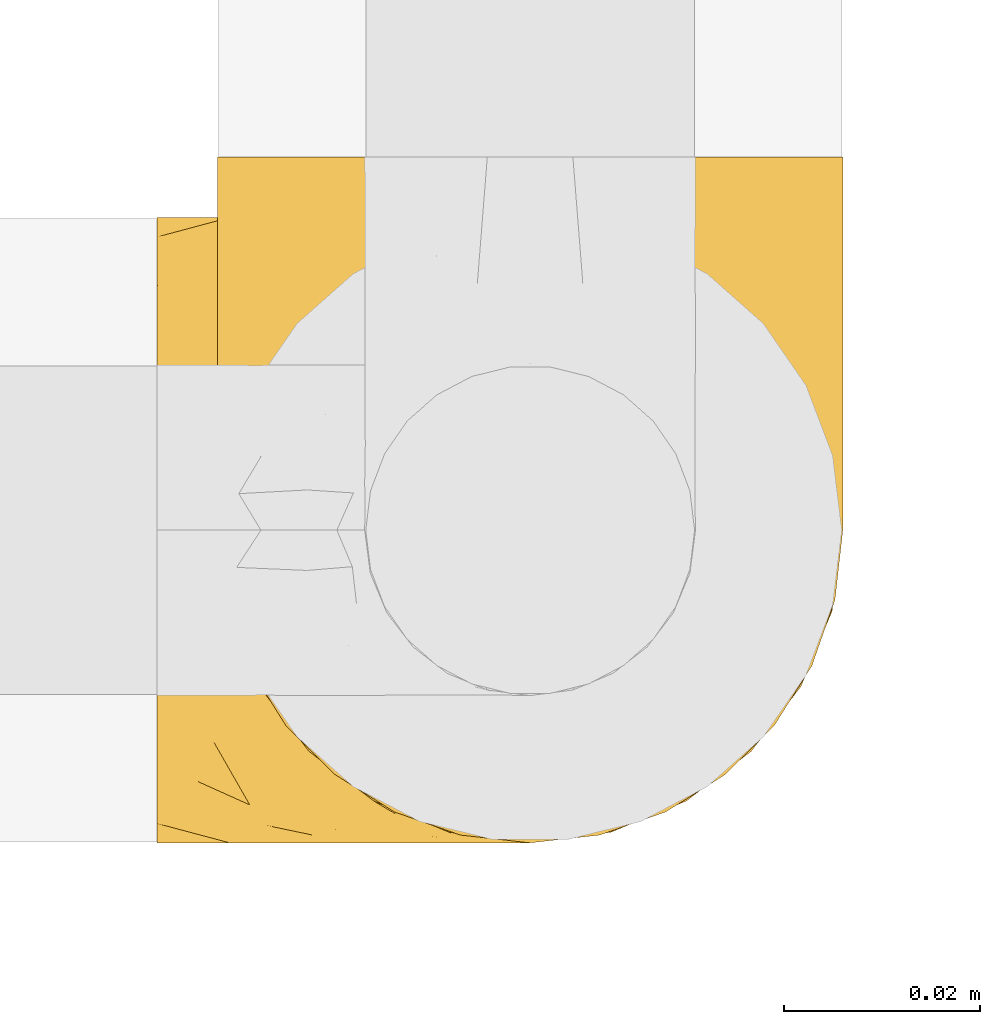
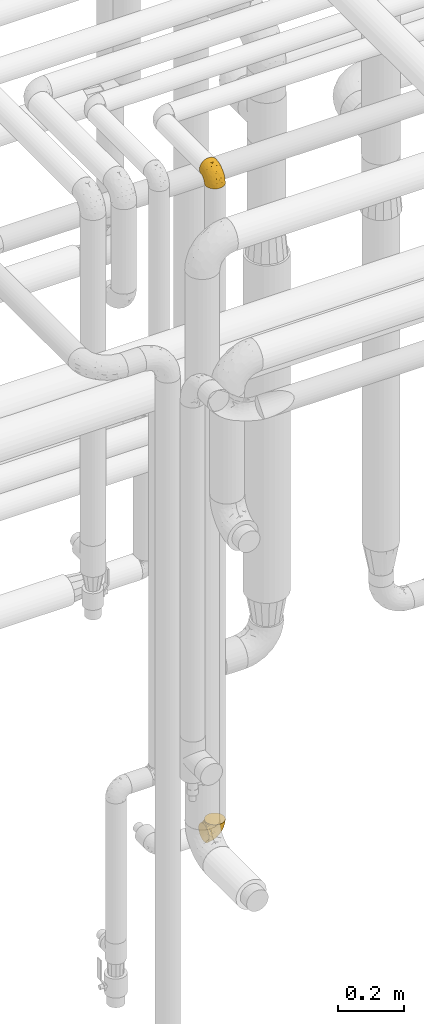
# One storey, part 437 of 827: 2 coverings.
"""IFC2X3 building model written with IfcOpenShell, lengths in millimetres."""

from ifc_helpers import new_model, entity, si_unit, converted_unit, derived_unit, direction, frame, origin, place, context, subcontext, project, spatial, faceted_brep, element, save


model = new_model("IFC2X3")

# Units and contexts
model_context = context("Model", 3, precision=0.01, world=origin(), true_north=direction((6.12303176911189e-17, 1.0)))
body_context = subcontext(model_context, "Body", "Model", "MODEL_VIEW")
ifc_project = project(units=[si_unit("LENGTHUNIT", "METRE", prefix="MILLI"), si_unit("AREAUNIT", "SQUARE_METRE"), si_unit("VOLUMEUNIT", "CUBIC_METRE"), converted_unit("PLANEANGLEUNIT", "DEGREE", entity("IfcRatioMeasure", 0.0174532925199433), si_unit("PLANEANGLEUNIT", "RADIAN"), dimensions=[0, 0, 0, 0, 0, 0, 0]), si_unit("MASSUNIT", "GRAM", prefix="KILO"), derived_unit("MASSDENSITYUNIT", [(si_unit("MASSUNIT", "GRAM", prefix="KILO"), 1), (si_unit("LENGTHUNIT", "METRE"), -3)]), derived_unit("MOMENTOFINERTIAUNIT", [(si_unit("LENGTHUNIT", "METRE"), 4)]), si_unit("TIMEUNIT", "SECOND"), si_unit("FREQUENCYUNIT", "HERTZ"), si_unit("THERMODYNAMICTEMPERATUREUNIT", "DEGREE_CELSIUS"), derived_unit("THERMALTRANSMITTANCEUNIT", [(si_unit("MASSUNIT", "GRAM", prefix="KILO"), 1), (si_unit("THERMODYNAMICTEMPERATUREUNIT", "KELVIN"), -1), (si_unit("TIMEUNIT", "SECOND"), -3)]), derived_unit("VOLUMETRICFLOWRATEUNIT", [(si_unit("LENGTHUNIT", "METRE"), 3), (si_unit("TIMEUNIT", "SECOND"), -1)]), derived_unit("MASSFLOWRATEUNIT", [(si_unit("MASSUNIT", "GRAM", prefix="KILO"), 1), (si_unit("TIMEUNIT", "SECOND"), -1)]), derived_unit("ROTATIONALFREQUENCYUNIT", [(si_unit("TIMEUNIT", "SECOND"), -1)]), si_unit("ELECTRICCURRENTUNIT", "AMPERE"), si_unit("ELECTRICVOLTAGEUNIT", "VOLT"), si_unit("POWERUNIT", "WATT"), si_unit("FORCEUNIT", "NEWTON", prefix="KILO"), si_unit("ILLUMINANCEUNIT", "LUX"), si_unit("LUMINOUSFLUXUNIT", "LUMEN"), si_unit("LUMINOUSINTENSITYUNIT", "CANDELA"), derived_unit("USERDEFINED", [(si_unit("MASSUNIT", "GRAM", prefix="KILO"), -1), (si_unit("LENGTHUNIT", "METRE"), -2), (si_unit("TIMEUNIT", "SECOND"), 3), (si_unit("LUMINOUSFLUXUNIT", "LUMEN"), 1)]), derived_unit("LINEARVELOCITYUNIT", [(si_unit("LENGTHUNIT", "METRE"), 1), (si_unit("TIMEUNIT", "SECOND"), -1)]), si_unit("PRESSUREUNIT", "PASCAL"), derived_unit("USERDEFINED", [(si_unit("LENGTHUNIT", "METRE"), -2), (si_unit("MASSUNIT", "GRAM", prefix="KILO"), 1), (si_unit("TIMEUNIT", "SECOND"), -2)]), derived_unit("LINEARFORCEUNIT", [(si_unit("MASSUNIT", "GRAM", prefix="KILO"), 1), (si_unit("LENGTHUNIT", "METRE"), 1), (si_unit("TIMEUNIT", "SECOND"), -2), (si_unit("LENGTHUNIT", "METRE"), -1)]), derived_unit("PLANARFORCEUNIT", [(si_unit("MASSUNIT", "GRAM", prefix="KILO"), 1), (si_unit("LENGTHUNIT", "METRE"), 1), (si_unit("TIMEUNIT", "SECOND"), -2), (si_unit("LENGTHUNIT", "METRE"), -2)])], contexts=[model_context])

# Site, building, storey
site_placement = place(None, origin())
site = spatial("IfcSite", under=ifc_project, at=site_placement, CompositionType="ELEMENT")
building_placement = place(site_placement, origin())
building = spatial("IfcBuilding", under=site, at=building_placement, CompositionType="ELEMENT")
storey_placement = place(building_placement, frame((0.0, 0.0, 28200.0)))
storey = spatial("IfcBuildingStorey", under=building, at=storey_placement, Name="08", CompositionType="ELEMENT", Elevation=28200.0)

# Coverings
covering_1_placement = place(storey_placement, frame((56084.69, 16164.49, 3160.4)))
element("IfcCovering", 1, at=covering_1_placement, inside=storey, Name=":ADSK_", ObjectType=":ADSK_", PredefinedType="INSULATION", context=body_context, shape_type="Brep", body=[
    faceted_brep([(40.53, 2.39, 1.6), (33.45, 1.6, 1.6), (26.35, 2.39, 1.6), (19.62, 4.75, 1.6), (13.58, 8.55, 1.6), (8.54, 13.59, 1.6), (4.75, 19.63, 1.6), (2.39, 26.36, 1.6), (1.6, 33.45, 1.6), (2.04, 37.35, 1.6), (2.39, 40.54, 1.6), (3.57, 43.9, 1.6), (4.75, 47.27, 1.6), (8.55, 53.31, 1.6), (13.59, 58.35, 1.6), (19.63, 62.14, 1.6), (26.36, 64.5, 1.6), (33.45, 65.3, 1.6), (40.54, 64.5, 1.6), (47.27, 62.14, 1.6), (53.31, 58.34, 1.6), (58.35, 53.3, 1.6), (62.14, 47.26, 1.6), (63.32, 43.89, 1.6), (64.5, 40.53, 1.6), (64.86, 37.35, 1.6), (65.08, 35.4, 1.6), (65.3, 33.45, 1.6), (64.5, 26.35, 1.6), (62.14, 19.62, 1.6), (58.34, 13.58, 1.6), (53.3, 8.54, 1.6), (47.26, 4.75, 1.6), (5.86, 71.45, 23.67), (4.27, 71.45, 27.51), (2.68, 71.45, 31.35), (2.11, 71.45, 35.67), (1.85, 71.45, 37.63), (1.6, 71.45, 39.6), (2.68, 71.45, 47.84), (5.86, 71.45, 55.52), (10.92, 71.45, 62.12), (17.52, 71.45, 67.18), (25.2, 71.45, 70.36), (33.45, 71.45, 71.45), (41.69, 71.45, 70.36), (49.37, 71.45, 67.18), (55.97, 71.45, 62.12), (61.03, 71.45, 55.52), (64.21, 71.45, 47.84), (65.3, 71.45, 39.6), (64.78, 71.45, 35.67), (64.21, 71.45, 31.35), (62.62, 71.45, 27.51), (61.03, 71.45, 23.67), (58.5, 71.45, 20.37), (55.97, 71.45, 17.07), (49.37, 71.45, 12.01), (41.69, 71.45, 8.83), (33.45, 71.45, 7.75), (25.2, 71.45, 8.83), (17.52, 71.45, 12.01), (10.92, 71.45, 17.07), (8.39, 71.45, 20.37), (64.03, 37.48, 33.94), (65.3, 38.54, 20.6), (65.3, 42.01, 24.07), (65.3, 45.49, 27.55), (65.3, 48.97, 31.03), (65.3, 52.45, 34.5), (33.45, 58.08, 68.79), (56.13, 40.84, 53.62), (61.0, 47.91, 50.17), (57.25, 55.67, 58.62), (44.44, 55.18, 67.51), (50.33, 45.13, 61.03), (51.72, 59.19, 64.5), (54.4, 11.67, 17.98), (41.87, 38.17, 61.71), (48.25, 28.82, 52.25), (64.6, 29.48, 16.72), (60.78, 32.11, 39.09), (61.71, 24.68, 25.86), (64.46, 55.82, 44.07), (55.78, 28.37, 44.36), (40.71, 9.18, 31.35), (42.87, 4.95, 17.72), (47.87, 11.17, 29.45), (62.12, 60.89, 52.37), (65.3, 55.35, 35.28), (65.3, 58.25, 36.06), (65.3, 61.15, 36.84), (65.3, 64.05, 37.61), (65.3, 65.9, 38.11), (65.3, 67.75, 38.61), (59.32, 16.27, 14.07), (49.35, 6.97, 13.65), (33.45, 4.25, 14.96), (62.53, 21.84, 13.32), (65.3, 33.94, 3.44), (65.3, 34.44, 5.29), (65.3, 35.43, 8.99), (65.3, 36.2, 11.89), (65.3, 36.98, 14.79), (65.3, 37.76, 17.69), (57.03, 18.84, 29.19), (52.84, 14.39, 28.91), (38.52, 51.68, 68.17), (33.45, 6.91, 28.33), (41.09, 26.05, 53.45), (33.45, 33.38, 58.56), (33.45, 22.05, 50.99), (44.35, 17.7, 43.14), (51.29, 19.21, 39.23), (33.45, 44.71, 66.13), (38.44, 17.7, 45.6), (33.45, 14.48, 39.66), (57.42, 66.98, 18.04), (61.06, 65.01, 22.76), (61.24, 61.98, 21.95), (64.58, 64.85, 32.18), (64.0, 62.15, 29.08), (64.21, 48.67, 20.77), (44.85, 63.81, 4.75), (61.42, 50.71, 11.03), (61.84, 48.45, 6.78), (59.03, 52.85, 5.68), (41.64, 67.6, 7.71), (38.8, 65.48, 4.42), (33.45, 67.1, 5.94), (54.12, 66.68, 14.52), (64.27, 43.2, 11.63), (63.33, 44.92, 6.6), (54.97, 58.1, 7.33), (54.91, 61.92, 12.48), (49.44, 63.17, 7.99), (49.79, 66.68, 11.14), (59.23, 56.7, 14.07), (62.42, 50.86, 15.37), (59.27, 54.42, 10.81), (64.6, 40.7, 7.89), (63.73, 57.76, 26.18), (50.25, 61.34, 5.8), (54.66, 59.9, 9.94), (62.35, 58.0, 22.23), (59.05, 62.43, 18.39), (64.34, 45.83, 17.71), (59.52, 58.99, 16.87), (63.71, 45.9, 13.24), (61.92, 67.3, 24.95), (64.52, 53.12, 26.59), (64.9, 49.43, 26.16), (63.33, 53.9, 22.11), (62.23, 52.92, 17.43), (22.04, 63.81, 4.75), (16.65, 61.35, 5.8), (17.46, 63.17, 7.99), (7.66, 56.72, 14.07), (12.13, 59.87, 10.06), (7.35, 54.39, 11.54), (25.25, 67.59, 7.71), (2.29, 40.71, 7.89), (1.6, 35.43, 8.99), (1.6, 36.2, 11.89), (1.6, 36.98, 14.79), (28.1, 65.48, 4.42), (4.51, 58.19, 22.42), (2.45, 55.78, 27.95), (5.62, 62.46, 22.22), (1.6, 69.6, 39.1), (1.6, 61.15, 36.84), (1.6, 64.05, 37.61), (1.6, 67.75, 38.61), (6.96, 67.39, 21.49), (4.16, 66.16, 26.52), (6.38, 58.11, 18.09), (7.84, 62.44, 18.39), (10.87, 61.95, 13.88), (17.1, 66.68, 11.14), (2.31, 64.85, 32.18), (1.6, 52.45, 34.5), (1.6, 48.97, 31.03), (2.62, 43.18, 11.65), (7.88, 52.88, 5.67), (5.05, 48.46, 6.81), (1.6, 34.44, 5.29), (1.6, 34.93, 7.14), (11.92, 58.11, 7.34), (1.6, 58.25, 36.06), (2.23, 60.72, 31.38), (2.95, 49.13, 19.83), (1.6, 45.49, 27.55), (3.29, 53.71, 22.94), (3.56, 44.93, 6.6), (9.57, 67.04, 17.93), (12.74, 66.6, 14.52), (2.39, 44.91, 17.45), (5.47, 50.72, 11.03), (1.6, 37.76, 17.69), (1.6, 38.54, 20.6), (3.46, 46.39, 12.33), (2.2, 57.7, 30.27), (1.6, 55.35, 35.28), (4.02, 62.73, 25.9), (1.6, 42.01, 24.07), (9.64, 55.67, 58.62), (4.35, 21.85, 13.32), (2.29, 29.49, 16.72), (2.43, 55.82, 44.07), (25.02, 38.17, 61.71), (22.45, 55.18, 67.51), (16.56, 45.12, 61.03), (5.89, 47.92, 50.18), (2.86, 37.47, 33.92), (6.1, 32.11, 39.08), (10.76, 40.85, 53.62), (28.37, 51.68, 68.17), (4.77, 60.89, 52.37), (15.17, 59.19, 64.5), (5.18, 24.69, 25.86), (7.56, 16.28, 14.07), (9.85, 18.85, 29.18), (19.01, 11.19, 29.46), (24.01, 4.95, 17.73), (26.18, 9.19, 31.37), (12.48, 11.68, 17.99), (25.8, 26.05, 53.45), (15.6, 19.23, 39.25), (14.04, 14.4, 28.92), (17.53, 6.97, 13.65), (18.64, 28.8, 52.23), (22.54, 17.7, 43.13), (11.1, 28.37, 44.36), (28.45, 17.7, 45.6)], [[[0, 1, 2, 3, 4, 5, 6, 7, 8, 9, 10, 11, 12, 13, 14, 15, 16, 17, 18, 19, 20, 21, 22, 23, 24, 25, 26, 27, 28, 29, 30, 31, 32]], [[33, 34, 35, 36, 37, 38, 39, 40, 41, 42, 43, 44, 45, 46, 47, 48, 49, 50, 51, 52, 53, 54, 55, 56, 57, 58, 59, 60, 61, 62, 63]], [[64, 65, 66, 67, 68, 69]], [[45, 44, 70]], [[71, 72, 73]], [[74, 75, 76]], [[77, 31, 30]], [[75, 78, 79]], [[27, 80, 28]], [[74, 46, 45]], [[64, 81, 82]], [[46, 76, 47]], [[83, 50, 49]], [[48, 47, 73]], [[71, 79, 84]], [[85, 86, 87]], [[49, 48, 88]], [[83, 69, 89, 90, 91, 92, 93, 94, 50]], [[95, 77, 30]], [[75, 74, 78]], [[87, 86, 96]], [[96, 86, 32]], [[96, 32, 31]], [[0, 86, 97]], [[83, 64, 69]], [[98, 80, 82]], [[73, 72, 88]], [[64, 80, 65]], [[1, 0, 97]], [[80, 27, 99, 100, 101, 102, 103, 104, 65]], [[77, 105, 106]], [[64, 82, 80]], [[70, 107, 45]], [[77, 95, 105]], [[82, 95, 98]], [[95, 30, 29]], [[74, 107, 78]], [[86, 0, 32]], [[72, 71, 81]], [[85, 108, 86]], [[76, 73, 47]], [[71, 84, 81]], [[109, 110, 111]], [[87, 112, 85]], [[79, 109, 112]], [[79, 112, 113]], [[88, 83, 49]], [[64, 83, 72]], [[31, 77, 96]], [[87, 96, 77]], [[98, 95, 29]], [[105, 95, 82]], [[81, 105, 82]], [[105, 84, 113]], [[29, 28, 98]], [[114, 107, 70]], [[80, 98, 28]], [[73, 75, 71]], [[79, 71, 75]], [[74, 76, 46]], [[73, 76, 75]], [[78, 107, 114]], [[45, 107, 74]], [[87, 113, 112]], [[115, 85, 112]], [[109, 79, 78]], [[113, 87, 106]], [[116, 115, 111]], [[116, 108, 85]], [[79, 113, 84]], [[109, 78, 110]], [[115, 109, 111]], [[85, 115, 116]], [[109, 115, 112]], [[72, 81, 64]], [[105, 81, 84]], [[73, 88, 48]], [[83, 88, 72]], [[86, 108, 97]], [[78, 114, 110]], [[113, 106, 105]], [[87, 77, 106]], [[117, 118, 119]], [[52, 120, 54, 53]], [[91, 120, 52]], [[91, 90, 120]], [[90, 121, 120]], [[122, 67, 66]], [[18, 123, 19]], [[124, 125, 126]], [[127, 59, 58]], [[128, 129, 127]], [[130, 57, 117]], [[131, 132, 125]], [[19, 133, 20]], [[128, 18, 17]], [[134, 135, 136]], [[137, 138, 139]], [[131, 103, 140]], [[22, 140, 23]], [[131, 65, 104, 103]], [[99, 27, 26, 25, 24, 101, 100]], [[141, 118, 121]], [[19, 123, 142]], [[52, 51, 50, 94, 93, 92, 91]], [[129, 128, 17]], [[117, 56, 118]], [[135, 134, 143]], [[139, 126, 133]], [[119, 144, 145]], [[127, 135, 123]], [[136, 58, 57]], [[101, 24, 23]], [[124, 138, 146]], [[140, 101, 23]], [[145, 147, 134]], [[140, 132, 131]], [[140, 103, 102, 101]], [[140, 22, 132]], [[146, 148, 124]], [[121, 69, 141]], [[55, 149, 118]], [[150, 151, 152]], [[147, 137, 134]], [[144, 150, 152]], [[152, 151, 122]], [[138, 122, 146]], [[59, 127, 129]], [[123, 18, 128]], [[58, 136, 127]], [[135, 127, 136]], [[121, 90, 89, 69]], [[120, 121, 149]], [[122, 66, 146]], [[153, 122, 138]], [[141, 69, 68]], [[127, 123, 128]], [[123, 135, 142]], [[143, 142, 135]], [[19, 142, 133]], [[66, 65, 146]], [[148, 65, 131]], [[22, 21, 132]], [[125, 132, 21]], [[126, 125, 21]], [[148, 125, 124]], [[21, 20, 126]], [[133, 126, 20]], [[139, 138, 124]], [[153, 138, 137]], [[126, 139, 124]], [[139, 133, 143]], [[147, 153, 137]], [[152, 122, 153]], [[134, 136, 130]], [[137, 139, 143]], [[144, 147, 145]], [[153, 147, 152]], [[65, 148, 146]], [[125, 148, 131]], [[141, 144, 119]], [[55, 54, 149]], [[137, 143, 134]], [[142, 143, 133]], [[130, 117, 145]], [[57, 56, 117]], [[134, 130, 145]], [[57, 130, 136]], [[150, 144, 141]], [[147, 144, 152]], [[141, 68, 150]], [[151, 68, 67]], [[117, 119, 145]], [[141, 119, 118]], [[68, 151, 150]], [[122, 151, 67]], [[118, 56, 55]], [[120, 149, 54]], [[118, 149, 121]], [[154, 155, 156]], [[157, 158, 159]], [[129, 160, 59]], [[161, 162, 163, 164]], [[165, 160, 129]], [[166, 167, 168]], [[169, 38, 37, 36, 35, 170, 171, 172]], [[63, 173, 174]], [[175, 176, 177]], [[60, 178, 61]], [[179, 35, 34, 33]], [[160, 60, 59]], [[180, 167, 181]], [[129, 17, 165]], [[182, 161, 164]], [[183, 13, 184]], [[9, 8, 185, 186, 162, 10]], [[187, 155, 15]], [[188, 179, 189]], [[187, 15, 14]], [[190, 191, 192]], [[182, 193, 161]], [[194, 176, 168]], [[176, 195, 177]], [[196, 190, 197]], [[11, 10, 162]], [[11, 161, 12]], [[187, 14, 183]], [[12, 161, 193]], [[156, 158, 177]], [[165, 17, 16]], [[194, 195, 176]], [[187, 159, 158]], [[179, 174, 189]], [[182, 164, 198, 199]], [[200, 199, 196]], [[193, 184, 13]], [[194, 168, 173]], [[201, 202, 189]], [[16, 154, 165]], [[160, 156, 178]], [[160, 165, 154]], [[178, 60, 160]], [[170, 35, 179]], [[188, 170, 179]], [[189, 174, 203]], [[174, 179, 33]], [[201, 189, 203]], [[181, 192, 191]], [[167, 180, 201]], [[192, 175, 190]], [[159, 190, 157]], [[15, 154, 16]], [[204, 196, 199]], [[204, 191, 190]], [[160, 154, 156]], [[15, 155, 154]], [[158, 155, 187]], [[203, 173, 168]], [[192, 181, 167]], [[190, 196, 204]], [[200, 196, 197]], [[184, 193, 182]], [[13, 12, 193]], [[200, 184, 182]], [[184, 200, 183]], [[187, 183, 197]], [[14, 13, 183]], [[162, 161, 11]], [[63, 62, 173]], [[174, 33, 63]], [[173, 62, 194]], [[174, 173, 203]], [[62, 61, 194]], [[195, 61, 178]], [[61, 195, 194]], [[177, 195, 178]], [[156, 177, 178]], [[175, 192, 166]], [[166, 168, 176]], [[167, 203, 168]], [[175, 166, 176]], [[167, 166, 192]], [[177, 157, 175]], [[190, 175, 157]], [[187, 197, 159]], [[190, 159, 197]], [[177, 158, 157]], [[155, 158, 156]], [[167, 201, 203]], [[200, 197, 183]], [[202, 201, 180]], [[202, 188, 189]], [[199, 200, 182]], [[41, 40, 205]], [[206, 207, 7]], [[208, 38, 169, 172, 171, 170, 188, 202, 180]], [[209, 210, 211]], [[212, 213, 214]], [[212, 215, 205]], [[43, 210, 216]], [[217, 40, 39]], [[216, 114, 70]], [[208, 213, 212]], [[205, 40, 217]], [[218, 42, 41]], [[216, 209, 114]], [[42, 218, 210]], [[214, 213, 219]], [[219, 220, 221]], [[199, 207, 213]], [[213, 207, 219]], [[8, 7, 207]], [[222, 223, 224]], [[4, 225, 5]], [[2, 97, 223]], [[110, 226, 111]], [[225, 220, 5]], [[227, 221, 228]], [[223, 229, 3]], [[2, 223, 3]], [[230, 231, 226]], [[224, 223, 108]], [[42, 210, 43]], [[230, 209, 211]], [[222, 225, 229]], [[38, 208, 39]], [[3, 229, 4]], [[213, 180, 181, 191, 204, 199]], [[220, 206, 6]], [[5, 220, 6]], [[207, 199, 198, 164, 163, 162, 186, 185, 8]], [[212, 214, 215]], [[218, 205, 211]], [[211, 215, 230]], [[226, 110, 209]], [[222, 231, 227]], [[222, 224, 231]], [[213, 208, 180]], [[217, 208, 212]], [[222, 229, 223]], [[225, 4, 229]], [[221, 220, 225]], [[206, 220, 219]], [[228, 221, 225]], [[214, 221, 232]], [[207, 206, 219]], [[44, 43, 70]], [[7, 6, 206]], [[230, 215, 232]], [[211, 205, 215]], [[205, 218, 41]], [[210, 218, 211]], [[43, 216, 70]], [[209, 216, 210]], [[233, 116, 111]], [[230, 232, 227]], [[224, 116, 233]], [[230, 226, 209]], [[224, 108, 116]], [[230, 227, 231]], [[221, 227, 232]], [[233, 226, 231]], [[225, 222, 228]], [[226, 233, 111]], [[224, 233, 231]], [[221, 214, 219]], [[214, 232, 215]], [[208, 217, 39]], [[205, 217, 212]], [[97, 2, 1]], [[97, 108, 223]], [[110, 114, 209]], [[227, 228, 222]]]),
])
covering_2_placement = place(storey_placement, frame((56078.54, 16164.49, 751.3)))
element("IfcCovering", 2, at=covering_2_placement, inside=storey, Name=":ADSK_", ObjectType=":ADSK_", PredefinedType="INSULATION", context=body_context, shape_type="Brep", body=[
    faceted_brep([(1.6, 40.53, 2.39), (1.6, 33.45, 1.6), (1.6, 26.35, 2.39), (1.6, 19.62, 4.75), (1.6, 13.58, 8.55), (1.6, 8.54, 13.59), (1.6, 4.75, 19.63), (1.6, 2.39, 26.36), (1.6, 1.6, 33.45), (1.6, 2.04, 37.35), (1.6, 2.39, 40.54), (1.6, 3.57, 43.9), (1.6, 4.75, 47.27), (1.6, 8.55, 53.31), (1.6, 13.59, 58.35), (1.6, 19.63, 62.14), (1.6, 26.36, 64.5), (1.6, 33.45, 65.3), (1.6, 40.54, 64.5), (1.6, 47.27, 62.14), (1.6, 53.31, 58.34), (1.6, 58.35, 53.3), (1.6, 62.14, 47.26), (1.6, 63.32, 43.89), (1.6, 64.5, 40.53), (1.6, 64.86, 37.35), (1.6, 65.08, 35.4), (1.6, 65.3, 33.45), (1.6, 64.5, 26.35), (1.6, 62.14, 19.62), (1.6, 58.34, 13.58), (1.6, 53.3, 8.54), (1.6, 47.26, 4.75), (23.67, 5.86, 71.45), (27.51, 4.27, 71.45), (31.35, 2.68, 71.45), (35.67, 2.11, 71.45), (37.63, 1.85, 71.45), (39.6, 1.6, 71.45), (47.84, 2.68, 71.45), (55.52, 5.86, 71.45), (62.12, 10.92, 71.45), (67.18, 17.52, 71.45), (70.36, 25.2, 71.45), (71.45, 33.45, 71.45), (70.36, 41.69, 71.45), (67.18, 49.37, 71.45), (62.12, 55.97, 71.45), (55.52, 61.03, 71.45), (47.84, 64.21, 71.45), (39.6, 65.3, 71.45), (35.67, 64.78, 71.45), (31.35, 64.21, 71.45), (27.51, 62.62, 71.45), (23.67, 61.03, 71.45), (20.37, 58.5, 71.45), (17.07, 55.97, 71.45), (12.01, 49.37, 71.45), (8.83, 41.69, 71.45), (7.75, 33.45, 71.45), (8.83, 25.2, 71.45), (12.01, 17.52, 71.45), (17.07, 10.92, 71.45), (20.37, 8.39, 71.45), (33.94, 64.03, 37.48), (20.6, 65.3, 38.54), (24.07, 65.3, 42.01), (27.55, 65.3, 45.49), (31.03, 65.3, 48.97), (34.5, 65.3, 52.45), (68.79, 33.45, 58.08), (53.62, 56.13, 40.84), (50.17, 61.0, 47.91), (58.62, 57.25, 55.67), (67.51, 44.44, 55.18), (61.03, 50.33, 45.13), (64.5, 51.72, 59.19), (17.98, 54.4, 11.67), (61.71, 41.87, 38.17), (52.25, 48.25, 28.82), (16.72, 64.6, 29.48), (39.09, 60.78, 32.11), (25.86, 61.71, 24.68), (44.07, 64.46, 55.82), (44.36, 55.78, 28.37), (31.35, 40.71, 9.18), (17.72, 42.87, 4.95), (29.45, 47.87, 11.17), (52.37, 62.12, 60.89), (35.28, 65.3, 55.35), (36.06, 65.3, 58.25), (36.84, 65.3, 61.15), (37.61, 65.3, 64.05), (38.11, 65.3, 65.9), (38.61, 65.3, 67.75), (14.07, 59.32, 16.27), (13.65, 49.35, 6.97), (14.96, 33.45, 4.25), (13.32, 62.53, 21.84), (3.44, 65.3, 33.94), (5.29, 65.3, 34.44), (8.99, 65.3, 35.43), (11.89, 65.3, 36.2), (14.79, 65.3, 36.98), (17.69, 65.3, 37.76), (29.19, 57.03, 18.84), (28.91, 52.84, 14.39), (68.17, 38.52, 51.68), (28.33, 33.45, 6.91), (53.45, 41.09, 26.05), (58.56, 33.45, 33.38), (50.99, 33.45, 22.05), (43.14, 44.35, 17.7), (39.23, 51.29, 19.21), (66.13, 33.45, 44.71), (45.6, 38.44, 17.7), (39.66, 33.45, 14.48), (18.04, 57.42, 66.98), (22.76, 61.06, 65.01), (21.95, 61.24, 61.98), (32.18, 64.58, 64.85), (29.08, 64.0, 62.15), (20.77, 64.21, 48.67), (4.75, 44.85, 63.81), (11.03, 61.42, 50.71), (6.78, 61.84, 48.45), (5.68, 59.03, 52.85), (7.71, 41.64, 67.6), (4.42, 38.8, 65.48), (5.94, 33.45, 67.1), (14.52, 54.12, 66.68), (11.63, 64.27, 43.2), (6.6, 63.33, 44.92), (7.33, 54.97, 58.1), (12.48, 54.91, 61.92), (7.99, 49.44, 63.17), (11.14, 49.79, 66.68), (14.07, 59.23, 56.7), (15.37, 62.42, 50.86), (10.81, 59.27, 54.42), (7.89, 64.6, 40.7), (26.18, 63.73, 57.76), (5.8, 50.25, 61.34), (9.94, 54.66, 59.9), (22.23, 62.35, 58.0), (18.39, 59.05, 62.43), (17.71, 64.34, 45.83), (16.87, 59.52, 58.99), (13.24, 63.71, 45.9), (24.95, 61.92, 67.3), (26.59, 64.52, 53.12), (26.16, 64.9, 49.43), (22.11, 63.33, 53.9), (17.43, 62.23, 52.92), (4.75, 22.04, 63.81), (5.8, 16.65, 61.35), (7.99, 17.46, 63.17), (14.07, 7.66, 56.72), (10.06, 12.13, 59.87), (11.54, 7.35, 54.39), (7.71, 25.25, 67.59), (7.89, 2.29, 40.71), (8.99, 1.6, 35.43), (11.89, 1.6, 36.2), (14.79, 1.6, 36.98), (4.42, 28.1, 65.48), (22.42, 4.51, 58.19), (27.95, 2.45, 55.78), (22.22, 5.62, 62.46), (36.84, 1.6, 61.15), (37.61, 1.6, 64.05), (38.61, 1.6, 67.75), (39.1, 1.6, 69.6), (21.49, 6.96, 67.39), (26.52, 4.16, 66.16), (18.09, 6.38, 58.11), (18.39, 7.84, 62.44), (13.88, 10.87, 61.95), (11.14, 17.1, 66.68), (32.18, 2.31, 64.85), (34.5, 1.6, 52.45), (31.03, 1.6, 48.97), (11.65, 2.62, 43.18), (5.67, 7.88, 52.88), (6.81, 5.05, 48.46), (5.29, 1.6, 34.44), (7.14, 1.6, 34.93), (7.34, 11.92, 58.11), (36.06, 1.6, 58.25), (31.38, 2.23, 60.72), (19.83, 2.95, 49.13), (27.55, 1.6, 45.49), (22.94, 3.29, 53.71), (6.6, 3.56, 44.93), (17.93, 9.57, 67.04), (14.52, 12.74, 66.6), (17.45, 2.39, 44.91), (11.03, 5.47, 50.72), (17.69, 1.6, 37.76), (20.6, 1.6, 38.54), (12.33, 3.46, 46.39), (25.9, 4.02, 62.73), (30.27, 2.2, 57.7), (35.28, 1.6, 55.35), (24.07, 1.6, 42.01), (58.62, 9.64, 55.67), (13.32, 4.35, 21.85), (16.72, 2.29, 29.49), (44.07, 2.43, 55.82), (61.71, 25.02, 38.17), (67.51, 22.45, 55.18), (61.03, 16.56, 45.12), (50.18, 5.89, 47.92), (33.92, 2.86, 37.47), (39.08, 6.1, 32.11), (53.62, 10.76, 40.85), (68.17, 28.37, 51.68), (52.37, 4.77, 60.89), (64.5, 15.17, 59.19), (25.86, 5.18, 24.69), (14.07, 7.56, 16.28), (29.18, 9.85, 18.85), (29.46, 19.01, 11.19), (17.73, 24.01, 4.95), (31.37, 26.18, 9.19), (17.99, 12.48, 11.68), (53.45, 25.8, 26.05), (39.25, 15.6, 19.23), (28.92, 14.04, 14.4), (13.65, 17.53, 6.97), (52.23, 18.64, 28.8), (43.13, 22.54, 17.7), (44.36, 11.1, 28.37), (45.6, 28.45, 17.7)], [[[0, 1, 2, 3, 4, 5, 6, 7, 8, 9, 10, 11, 12, 13, 14, 15, 16, 17, 18, 19, 20, 21, 22, 23, 24, 25, 26, 27, 28, 29, 30, 31, 32]], [[33, 34, 35, 36, 37, 38, 39, 40, 41, 42, 43, 44, 45, 46, 47, 48, 49, 50, 51, 52, 53, 54, 55, 56, 57, 58, 59, 60, 61, 62, 63]], [[64, 65, 66, 67, 68, 69]], [[45, 44, 70]], [[71, 72, 73]], [[74, 75, 76]], [[77, 31, 30]], [[75, 78, 79]], [[27, 80, 28]], [[74, 46, 45]], [[64, 81, 82]], [[46, 76, 47]], [[83, 50, 49]], [[48, 47, 73]], [[71, 79, 84]], [[85, 86, 87]], [[49, 48, 88]], [[83, 69, 89, 90, 91, 92, 93, 94, 50]], [[95, 77, 30]], [[75, 74, 78]], [[87, 86, 96]], [[96, 86, 32]], [[96, 32, 31]], [[0, 86, 97]], [[83, 64, 69]], [[98, 80, 82]], [[73, 72, 88]], [[64, 80, 65]], [[1, 0, 97]], [[80, 27, 99, 100, 101, 102, 103, 104, 65]], [[77, 105, 106]], [[64, 82, 80]], [[70, 107, 45]], [[77, 95, 105]], [[82, 95, 98]], [[95, 30, 29]], [[74, 107, 78]], [[86, 0, 32]], [[72, 71, 81]], [[85, 108, 86]], [[76, 73, 47]], [[71, 84, 81]], [[109, 110, 111]], [[87, 112, 85]], [[79, 109, 112]], [[79, 112, 113]], [[88, 83, 49]], [[64, 83, 72]], [[31, 77, 96]], [[87, 96, 77]], [[98, 95, 29]], [[105, 95, 82]], [[81, 105, 82]], [[105, 84, 113]], [[29, 28, 98]], [[114, 107, 70]], [[80, 98, 28]], [[73, 75, 71]], [[79, 71, 75]], [[74, 76, 46]], [[73, 76, 75]], [[78, 107, 114]], [[45, 107, 74]], [[87, 113, 112]], [[115, 85, 112]], [[109, 79, 78]], [[113, 87, 106]], [[116, 115, 111]], [[116, 108, 85]], [[79, 113, 84]], [[109, 78, 110]], [[115, 109, 111]], [[85, 115, 116]], [[109, 115, 112]], [[72, 81, 64]], [[105, 81, 84]], [[73, 88, 48]], [[83, 88, 72]], [[86, 108, 97]], [[78, 114, 110]], [[113, 106, 105]], [[87, 77, 106]], [[117, 118, 119]], [[52, 120, 54, 53]], [[91, 120, 52]], [[91, 90, 120]], [[121, 90, 89, 69]], [[122, 67, 66]], [[18, 123, 19]], [[124, 125, 126]], [[127, 59, 58]], [[128, 129, 127]], [[130, 57, 117]], [[131, 132, 125]], [[19, 133, 20]], [[128, 18, 17]], [[134, 135, 136]], [[137, 138, 139]], [[131, 103, 140]], [[22, 140, 23]], [[131, 65, 104, 103]], [[26, 25, 24, 101, 100, 99, 27]], [[141, 118, 121]], [[19, 123, 142]], [[52, 51, 50, 94, 93, 92, 91]], [[129, 128, 17]], [[117, 56, 118]], [[135, 134, 143]], [[139, 126, 133]], [[119, 144, 145]], [[127, 135, 123]], [[136, 58, 57]], [[101, 24, 23]], [[124, 138, 146]], [[140, 101, 23]], [[145, 147, 134]], [[140, 132, 131]], [[140, 103, 102, 101]], [[140, 22, 132]], [[146, 148, 124]], [[121, 69, 141]], [[55, 149, 118]], [[150, 151, 152]], [[147, 137, 134]], [[144, 150, 152]], [[152, 151, 122]], [[138, 122, 146]], [[59, 127, 129]], [[123, 18, 128]], [[58, 136, 127]], [[135, 127, 136]], [[150, 144, 141]], [[120, 121, 149]], [[122, 66, 146]], [[153, 122, 138]], [[141, 69, 68]], [[127, 123, 128]], [[123, 135, 142]], [[143, 142, 135]], [[19, 142, 133]], [[66, 65, 146]], [[148, 65, 131]], [[22, 21, 132]], [[125, 132, 21]], [[126, 125, 21]], [[148, 125, 124]], [[21, 20, 126]], [[133, 126, 20]], [[139, 138, 124]], [[153, 138, 137]], [[126, 139, 124]], [[139, 133, 143]], [[147, 153, 137]], [[152, 122, 153]], [[134, 136, 130]], [[137, 139, 143]], [[144, 147, 145]], [[153, 147, 152]], [[65, 148, 146]], [[125, 148, 131]], [[141, 144, 119]], [[55, 54, 149]], [[137, 143, 134]], [[142, 143, 133]], [[130, 117, 145]], [[57, 56, 117]], [[134, 130, 145]], [[57, 130, 136]], [[90, 121, 120]], [[147, 144, 152]], [[141, 68, 150]], [[151, 68, 67]], [[117, 119, 145]], [[141, 119, 118]], [[68, 151, 150]], [[122, 151, 67]], [[118, 56, 55]], [[120, 149, 54]], [[118, 149, 121]], [[154, 155, 156]], [[157, 158, 159]], [[129, 160, 59]], [[161, 162, 163, 164]], [[165, 160, 129]], [[166, 167, 168]], [[37, 36, 35, 169, 170, 171, 172, 38]], [[63, 173, 174]], [[175, 176, 177]], [[60, 178, 61]], [[179, 35, 34, 33]], [[160, 60, 59]], [[180, 167, 181]], [[129, 17, 165]], [[182, 161, 164]], [[183, 13, 184]], [[9, 8, 185, 186, 162, 10]], [[187, 155, 15]], [[188, 179, 189]], [[187, 15, 14]], [[190, 191, 192]], [[182, 193, 161]], [[194, 176, 168]], [[176, 195, 177]], [[196, 190, 197]], [[11, 10, 162]], [[11, 161, 12]], [[187, 14, 183]], [[12, 161, 193]], [[156, 158, 177]], [[165, 17, 16]], [[194, 195, 176]], [[187, 159, 158]], [[179, 174, 189]], [[182, 164, 198, 199]], [[200, 199, 196]], [[193, 184, 13]], [[174, 173, 201]], [[202, 203, 189]], [[16, 154, 165]], [[160, 156, 178]], [[160, 165, 154]], [[178, 60, 160]], [[169, 35, 179]], [[188, 169, 179]], [[189, 174, 201]], [[174, 179, 33]], [[202, 189, 201]], [[181, 192, 191]], [[167, 180, 202]], [[192, 175, 190]], [[159, 190, 157]], [[15, 154, 16]], [[204, 196, 199]], [[204, 191, 190]], [[160, 154, 156]], [[15, 155, 154]], [[158, 155, 187]], [[201, 173, 168]], [[192, 181, 167]], [[190, 196, 204]], [[200, 196, 197]], [[184, 193, 182]], [[13, 12, 193]], [[200, 184, 182]], [[184, 200, 183]], [[187, 183, 197]], [[14, 13, 183]], [[162, 161, 11]], [[62, 173, 63]], [[174, 33, 63]], [[194, 173, 62]], [[173, 194, 168]], [[62, 61, 194]], [[195, 61, 178]], [[61, 195, 194]], [[177, 195, 178]], [[156, 177, 178]], [[175, 192, 166]], [[166, 168, 176]], [[167, 201, 168]], [[175, 166, 176]], [[167, 166, 192]], [[177, 157, 175]], [[190, 175, 157]], [[187, 197, 159]], [[190, 159, 197]], [[177, 158, 157]], [[155, 158, 156]], [[167, 202, 201]], [[200, 197, 183]], [[203, 202, 180]], [[203, 188, 189]], [[199, 200, 182]], [[41, 40, 205]], [[206, 207, 7]], [[208, 38, 172, 171, 170, 169, 188, 203, 180]], [[209, 210, 211]], [[212, 213, 214]], [[212, 215, 205]], [[43, 210, 216]], [[217, 40, 39]], [[216, 114, 70]], [[208, 213, 212]], [[205, 40, 217]], [[218, 42, 41]], [[216, 209, 114]], [[42, 218, 210]], [[214, 213, 219]], [[219, 220, 221]], [[199, 207, 213]], [[213, 207, 219]], [[8, 7, 207]], [[222, 223, 224]], [[4, 225, 5]], [[2, 97, 223]], [[110, 226, 111]], [[225, 220, 5]], [[227, 221, 228]], [[223, 229, 3]], [[2, 223, 3]], [[230, 231, 226]], [[224, 223, 108]], [[42, 210, 43]], [[230, 209, 211]], [[222, 225, 229]], [[38, 208, 39]], [[3, 229, 4]], [[213, 180, 181, 191, 204, 199]], [[220, 206, 6]], [[5, 220, 6]], [[207, 199, 198, 164, 163, 162, 186, 185, 8]], [[212, 214, 215]], [[218, 205, 211]], [[211, 215, 230]], [[226, 110, 209]], [[222, 231, 227]], [[222, 224, 231]], [[213, 208, 180]], [[217, 208, 212]], [[222, 229, 223]], [[225, 4, 229]], [[221, 220, 225]], [[206, 220, 219]], [[228, 221, 225]], [[214, 221, 232]], [[207, 206, 219]], [[44, 43, 70]], [[7, 6, 206]], [[230, 215, 232]], [[211, 205, 215]], [[205, 218, 41]], [[210, 218, 211]], [[43, 216, 70]], [[209, 216, 210]], [[233, 116, 111]], [[230, 232, 227]], [[224, 116, 233]], [[230, 226, 209]], [[224, 108, 116]], [[230, 227, 231]], [[221, 227, 232]], [[233, 226, 231]], [[225, 222, 228]], [[226, 233, 111]], [[224, 233, 231]], [[221, 214, 219]], [[214, 232, 215]], [[208, 217, 39]], [[205, 217, 212]], [[97, 2, 1]], [[97, 108, 223]], [[110, 114, 209]], [[227, 228, 222]]]),
])

save(model, "model.ifc")
